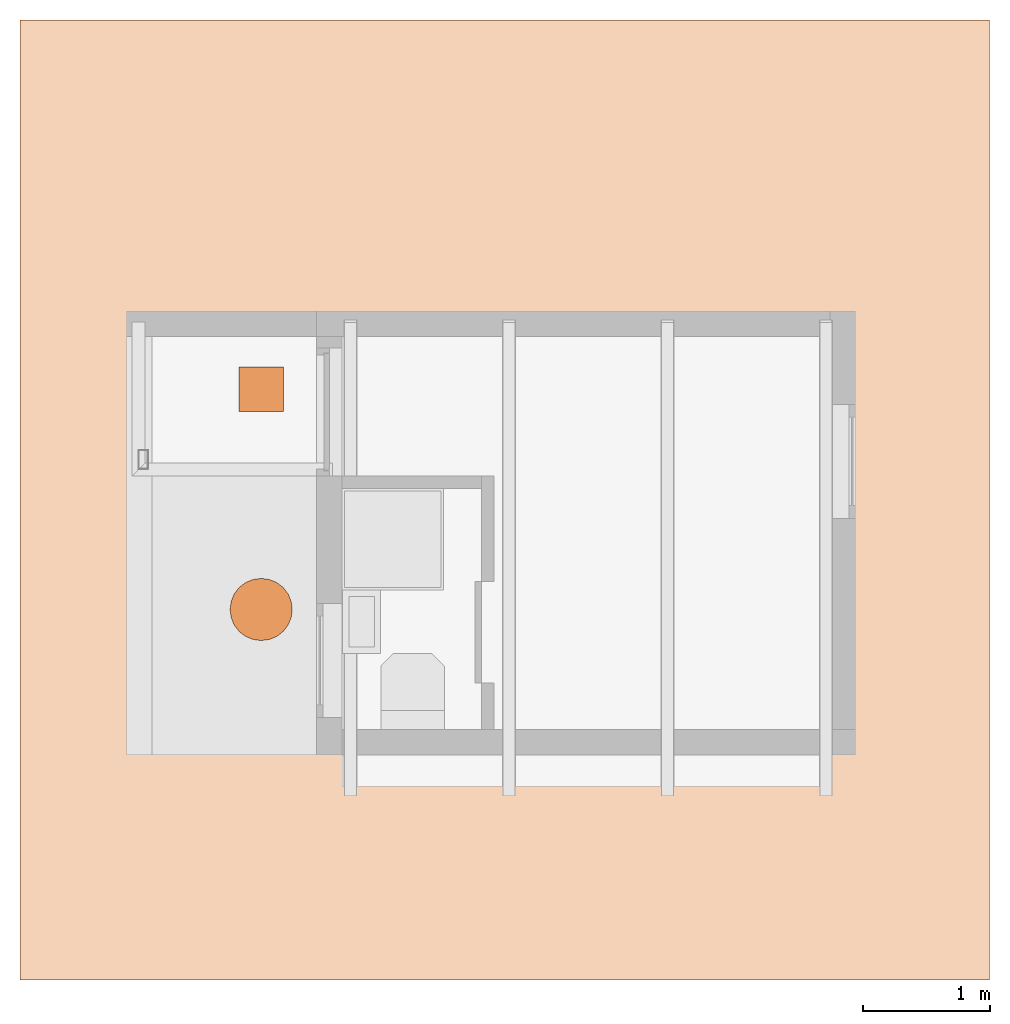
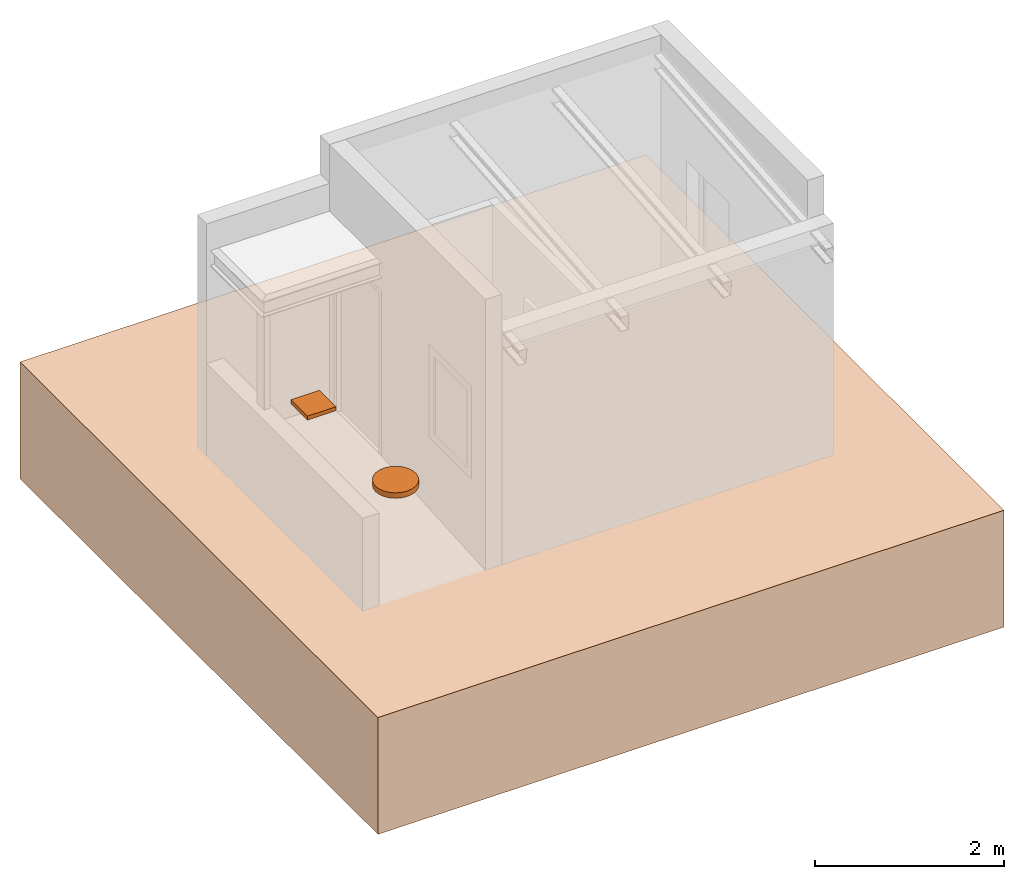
# Not in any storey, part 5 of 5: 2 proxies, 1 geographic element.
"""IFC4 model written with IfcOpenShell, lengths in millimetres."""

import ifcopenshell
import ifcopenshell.guid

model = None  # the IFC model being written
_history = None  # IfcOwnerHistory: only IFC2X3 demands one
_inside = {}  # id of a spatial element -> (the spatial element, [elements in it])
_under = {}  # id of a project, library or spatial element -> (it, [spatial elements below it])
_declared = {}  # id of a project -> (the project, [libraries it declares])
_typed = {}  # id of a type object -> (the type object, [elements of that type])
_made_of = {}  # id of a material, layer set ... -> (it, [elements and type objects made of it])


def new_model(schema):
    """Start an empty IFC model of exactly this schema.

    Asked for "IFC4X3", IfcOpenShell would pick the latest addendum, in which some entities
    have other attributes; the version numbers below select the first issue.
    IFC2X3 requires an IfcOwnerHistory on every rooted entity: one is made here for all.
    """
    global model, _history
    if schema == "IFC4X3":
        model = ifcopenshell.file(schema_version=(4, 3, 0, 0))
    else:
        model = ifcopenshell.file(schema=schema)
    _inside.clear()
    _under.clear()
    _declared.clear()
    _typed.clear()
    _made_of.clear()
    _history = None
    if model.schema == "IFC2X3":
        org = make("IfcOrganization", Name="unknown")
        user = make(
            "IfcPersonAndOrganization",
            ThePerson=make("IfcPerson", FamilyName="unknown"),
            TheOrganization=org,
        )
        app = make(
            "IfcApplication",
            ApplicationDeveloper=org,
            Version="unknown",
            ApplicationFullName="unknown",
            ApplicationIdentifier="unknown",
        )
        _history = make(
            "IfcOwnerHistory",
            OwningUser=user,
            OwningApplication=app,
            ChangeAction="ADDED",
            CreationDate=0,
        )
    return model


def make(cls, **values):
    """One entity of the class cls with the attributes given. An attribute that is None is left unset."""
    return model.create_entity(
        cls, **{name: value for name, value in values.items() if value is not None}
    )


def entity(cls, *values):
    """Any entity or typed value of the class cls, its attributes in the order of the schema. None: left unset."""
    e = model.create_entity(cls)
    for i, value in enumerate(values):
        if value is not None:
            e[i] = value
    return e


def rooted(cls, **values):
    """An entity with a GlobalId (a new one), such as an element, a storey or a relation."""
    return make(cls, GlobalId=ifcopenshell.guid.new(), OwnerHistory=_history, **values)


def si_unit(unit_type, name, prefix=None):
    """IfcSIUnit, for example si_unit("LENGTHUNIT", "METRE", prefix="MILLI")."""
    return make("IfcSIUnit", UnitType=unit_type, Prefix=prefix, Name=name)


def converted_unit(unit_type, name, factor, base, dimensions=None, offset=None):
    """IfcConversionBasedUnit, such as the inch: factor (a typed value) times the base unit."""
    return make(
        "IfcConversionBasedUnit"
        if offset is None
        else "IfcConversionBasedUnitWithOffset",
        ConversionOffset=offset,
        Dimensions=None
        if dimensions is None
        else entity("IfcDimensionalExponents", *dimensions),
        UnitType=unit_type,
        Name=name,
        ConversionFactor=make(
            "IfcMeasureWithUnit", ValueComponent=factor, UnitComponent=base
        ),
    )


def assignment(units):
    """IfcUnitAssignment: the units of a project."""
    return None if units is None else make("IfcUnitAssignment", Units=units)


def point(xyz):
    """IfcCartesianPoint."""
    return None if xyz is None else make("IfcCartesianPoint", Coordinates=xyz)


def direction(xyz):
    """IfcDirection."""
    return None if xyz is None else make("IfcDirection", DirectionRatios=xyz)


def frame(location, z_axis=None, x_axis=None):
    """IfcAxis2Placement3D, a coordinate frame: its origin and axes. An axis left out is left unset."""
    return make(
        "IfcAxis2Placement3D",
        Location=point(location),
        Axis=direction(z_axis),
        RefDirection=direction(x_axis),
    )


def frame_2d(location, x_axis=None):
    """IfcAxis2Placement2D, a coordinate frame in the plane: its origin and x axis."""
    return make(
        "IfcAxis2Placement2D", Location=point(location), RefDirection=direction(x_axis)
    )


def origin_with_axes():
    """The frame at (0, 0, 0) with the z axis (0, 0, 1) and the x axis (1, 0, 0) written out."""
    return frame((0.0, 0.0, 0.0), z_axis=(0.0, 0.0, 1.0), x_axis=(1.0, 0.0, 0.0))


def origin_2d_with_axis():
    """The frame at (0, 0) in the plane with the x axis (1, 0) written out."""
    return frame_2d((0.0, 0.0), x_axis=(1.0, 0.0))


def place(relative_to, where):
    """IfcLocalPlacement: puts the frame where relative to a parent placement (None: the world)."""
    return make(
        "IfcLocalPlacement", PlacementRelTo=relative_to, RelativePlacement=where
    )


def context(
    kind, dimensions, precision=None, world=None, true_north=None, identifier=None
):
    """IfcGeometricRepresentationContext, for example the 3D "Model" context."""
    return make(
        "IfcGeometricRepresentationContext",
        ContextIdentifier=identifier,
        ContextType=kind,
        CoordinateSpaceDimension=dimensions,
        Precision=precision,
        WorldCoordinateSystem=world,
        TrueNorth=true_north,
    )


def subcontext(parent, identifier, kind, view, scale=None):
    """IfcGeometricRepresentationSubContext, for example "Body" below "Model"."""
    return make(
        "IfcGeometricRepresentationSubContext",
        ContextIdentifier=identifier,
        ContextType=kind,
        ParentContext=parent,
        TargetScale=scale,
        TargetView=view,
    )


def project(units=None, contexts=None):
    """IfcProject with its units and contexts."""
    return rooted(
        "IfcProject",
        Name="project",
        RepresentationContexts=contexts,
        UnitsInContext=assignment(units),
    )


def point_list(points):
    """IfcCartesianPointList2D or 3D."""
    cls = (
        "IfcCartesianPointList2D" if len(points[0]) == 2 else "IfcCartesianPointList3D"
    )
    return make(cls, CoordList=points)


def polygons(points, faces, closed=None, point_numbers=None):
    """IfcPolygonalFaceSet: a face is its outer loop, then its inner loops; points numbered from 1."""
    made = []
    for loops in faces:
        if len(loops) == 1:
            made.append(make("IfcIndexedPolygonalFace", CoordIndex=loops[0]))
        else:
            made.append(
                make(
                    "IfcIndexedPolygonalFaceWithVoids",
                    CoordIndex=loops[0],
                    InnerCoordIndices=loops[1:],
                )
            )
    return make(
        "IfcPolygonalFaceSet",
        Coordinates=point_list(points),
        Closed=closed,
        Faces=made,
        PnIndex=point_numbers,
    )


def shape(context_of_items, identifier, shape_type, items):
    """IfcShapeRepresentation: the items that make up one representation, for example the "Body"."""
    return make(
        "IfcShapeRepresentation",
        ContextOfItems=context_of_items,
        RepresentationIdentifier=identifier,
        RepresentationType=shape_type,
        Items=items,
    )


def source(mapping_origin, context_of_items, identifier, shape_type, items):
    """IfcRepresentationMap: a shape defined once, which mapped items show again and again."""
    return make(
        "IfcRepresentationMap",
        MappingOrigin=mapping_origin,
        MappedRepresentation=shape(context_of_items, identifier, shape_type, items),
    )


def transform(
    local_origin,
    x_axis=None,
    y_axis=None,
    z_axis=None,
    scale=None,
    scale2=None,
    scale3=None,
    uniform=True,
):
    """IfcCartesianTransformationOperator3D, or its non-uniform kind. x_axis, y_axis, z_axis: its Axis1, 2, 3."""
    if uniform:
        return make(
            "IfcCartesianTransformationOperator3D",
            Axis1=direction(x_axis),
            Axis2=direction(y_axis),
            LocalOrigin=point(local_origin),
            Scale=scale,
            Axis3=direction(z_axis),
        )
    return make(
        "IfcCartesianTransformationOperator3DnonUniform",
        Axis1=direction(x_axis),
        Axis2=direction(y_axis),
        LocalOrigin=point(local_origin),
        Scale=scale,
        Axis3=direction(z_axis),
        Scale2=scale2,
        Scale3=scale3,
    )


def mapped(mapping_source, mapping_target):
    """IfcMappedItem: shows the shape of a source again, moved by a transform."""
    return make(
        "IfcMappedItem", MappingSource=mapping_source, MappingTarget=mapping_target
    )


def material(Name=None, Category=None):
    """IfcMaterial."""
    return make("IfcMaterial", Name=Name, Category=Category)


def made_of(thing, what):
    """Note that an element or type object is made of a material, layer set ...; save() writes the relation."""
    if what is not None:
        _made_of.setdefault(what.id(), (what, []))[1].append(thing)
    return thing


def type_object(cls, material=None, **own):
    """A type object (cls), such as IfcWallType, which elements share."""
    return made_of(rooted(cls, **own), material)


def type_shapes(of_type, sources):
    """Give a type object the sources (RepresentationMaps) that its elements show as mapped items."""
    of_type.RepresentationMaps = sources


def element(
    cls,
    number,
    at=None,
    inside=None,
    cuts=None,
    type_object=None,
    material=None,
    context=None,
    identifier="Body",
    shape_type=None,
    held_by="IfcProductDefinitionShape",
    body=None,
    shapes=None,
    **own,
):
    """One element of the class cls, such as IfcWall. Its Tag is "e" and its number.

    at: its placement. inside: the storey or other place that contains it. cuts: it is an
    opening in that element (IfcRelVoidsElement). A single representation is given by context,
    identifier, shape_type and body (its items); several are given by shapes. held_by: the class
    of the entity that holds the representations. save() writes the other relations.
    """
    e = rooted(cls, Tag="e%d" % number, ObjectPlacement=at, **own)
    if body is not None:
        shapes = [shape(context, identifier, shape_type, body)]
    if shapes is not None:
        e.Representation = make(held_by, Representations=shapes)
    if inside is not None:
        _inside.setdefault(inside.id(), (inside, []))[1].append(e)
    if cuts is not None:
        rooted(
            "IfcRelVoidsElement", RelatingBuildingElement=cuts, RelatedOpeningElement=e
        )
    if type_object is not None:
        _typed.setdefault(type_object.id(), (type_object, []))[1].append(e)
    return made_of(e, material)


def aggregate(whole, parts):
    """IfcRelAggregates: a whole, such as a stair, and the parts it consists of."""
    return rooted("IfcRelAggregates", RelatingObject=whole, RelatedObjects=parts)


def save(model, path):
    """Write the relations noted so far, then the file.

    IfcRelAggregates (storeys below a building ...), IfcRelContainedInSpatialStructure (elements
    in a storey), IfcRelDefinesByType, IfcRelAssociatesMaterial and IfcRelDeclares: one each for
    every whole, place, type object, material and project.
    """
    for whole, parts in _under.values():
        aggregate(whole, parts)
    for where, things in _inside.values():
        rooted(
            "IfcRelContainedInSpatialStructure",
            RelatedElements=things,
            RelatingStructure=where,
        )
    for kind, things in _typed.values():
        rooted("IfcRelDefinesByType", RelatedObjects=things, RelatingType=kind)
    for what, things in _made_of.values():
        rooted("IfcRelAssociatesMaterial", RelatedObjects=things, RelatingMaterial=what)
    for by, libraries in _declared.values():
        rooted("IfcRelDeclares", RelatingContext=by, RelatedDefinitions=libraries)
    model.write(path)


model = new_model("IFC4")

# Units and contexts
model_context = context("Model", 3, precision=1e-05, world=origin_with_axes())
plan_context = context("Plan", 2, precision=1e-05, world=origin_2d_with_axis())
body_context = subcontext(model_context, "Body", "Model", "MODEL_VIEW")
ifc_project = project(units=[converted_unit("PLANEANGLEUNIT", "degree", entity("IfcReal", 0.0174532925199433), si_unit("PLANEANGLEUNIT", "RADIAN"), dimensions=[0, 0, 0, 0, 0, 0, 0]), si_unit("AREAUNIT", "SQUARE_METRE"), si_unit("VOLUMEUNIT", "CUBIC_METRE"), si_unit("LENGTHUNIT", "METRE", prefix="MILLI")], contexts=[model_context, plan_context])

# Proxies
building_element_proxy_type_1 = type_object("IfcBuildingElementProxyType", Name="Rectangle Tag - 1:50", PredefinedType="COMPLEX")
shared_shape_1 = source(origin_with_axes(), body_context, "Body", "Tessellation", [
    polygons([(-174.999877929688, -174.999954223633, -24.9999732971191), (-174.999877929688, 174.999954223633, -24.9999732971191), (-174.999877929688, -174.999954223633, 24.9999732971191), (-174.999877929688, 174.999954223633, 24.9999732971191), (175.000030517578, 174.999954223633, -24.9999732971191), (175.000030517578, 174.999954223633, 24.9999732971191), (175.000030517578, -174.999954223633, -24.9999732971191), (175.000030517578, -174.999954223633, 24.9999732971191)], [[[3, 2, 1]], [[3, 4, 2]], [[6, 5, 2]], [[6, 2, 4]], [[6, 7, 5]], [[6, 8, 7]], [[7, 8, 3]], [[7, 3, 1]], [[2, 5, 7]], [[2, 7, 1]], [[6, 4, 3]], [[6, 3, 8]]]),
])
type_shapes(building_element_proxy_type_1, [shared_shape_1])
proxy_1_placement = place(None, frame((-437.147080898285, 2881.8724155426, 393.21556687355), z_axis=(0.0, 0.0, 1.0), x_axis=(1.0, 0.0, 0.0)))
element("IfcBuildingElementProxy", 1, at=proxy_1_placement, type_object=building_element_proxy_type_1, PredefinedType="COMPLEX", context=body_context, shape_type="MappedRepresentation", body=[
    mapped(shared_shape_1, transform((0.0, 0.0, 0.0), x_axis=(1.0, 0.0, 0.0), y_axis=(0.0, 1.0, 0.0), z_axis=(0.0, 0.0, 1.0), scale=1.0)),
])
building_element_proxy_type_2 = type_object("IfcBuildingElementProxyType", Name="Tag Circle - 980 - 1:50", PredefinedType="COMPLEX")
shared_shape_2 = source(origin_with_axes(), body_context, "Body", "Tessellation", [
    polygons([(-1.85985767841339, -244.999847412109, -34.9999847412109), (-1.85985767841339, -244.999847412109, 35.0000076293945), (1.8597697019577, -244.999847412109, -34.9999847412109), (1.8597697019577, -244.999847412109, 35.0000076293945), (1.8597697019577, 245.000030517578, -34.9999847412109), (1.8597697019577, 245.000030517578, 35.0000076293945), (-1.85985767841339, 245.000030517578, -34.9999847412109), (-1.85985767841339, 245.000030517578, 35.0000076293945), (-64.7891464233398, -236.715057373047, -34.9999847412109), (-123.42992401123, -212.425247192383, -34.9999847412109), (-173.785873413086, -173.785766601562, -34.9999847412109), (-212.425384521484, -123.429817199707, -34.9999847412109), (-236.715148925781, -64.7890319824219, -34.9999847412109), (-244.999969482422, -1.8597309589386, -34.9999847412109), (-244.999969482422, 1.85989630222321, -34.9999847412109), (-236.715148925781, 64.789176940918, -34.9999847412109), (-212.425384521484, 123.429954528809, -34.9999847412109), (-173.785873413086, 173.785934448242, -34.9999847412109), (-123.42992401123, 212.425445556641, -34.9999847412109), (-64.7891464233398, 236.715209960938, -34.9999847412109), (64.7890701293945, 236.715209960938, -34.9999847412109), (123.42985534668, 212.425445556641, -34.9999847412109), (173.78581237793, 173.785934448242, -34.9999847412109), (212.42529296875, 123.429954528809, -34.9999847412109), (236.715103149414, 64.789176940918, -34.9999847412109), (244.999877929688, 1.85989630222321, -34.9999847412109), (244.999877929688, -1.8597309589386, -34.9999847412109), (236.715103149414, -64.7890319824219, -34.9999847412109), (212.42529296875, -123.429817199707, -34.9999847412109), (173.78581237793, -173.785766601562, -34.9999847412109), (123.42985534668, -212.425247192383, -34.9999847412109), (64.7890701293945, -236.715057373047, -34.9999847412109), (-244.999969482422, 1.85989630222321, 35.0000076293945), (-244.999969482422, -1.8597309589386, 35.0000076293945), (-236.715148925781, -64.7890319824219, 35.0000076293945), (-212.425384521484, -123.429817199707, 35.0000076293945), (-173.785873413086, -173.785766601562, 35.0000076293945), (-123.42992401123, -212.425247192383, 35.0000076293945), (-64.7891464233398, -236.715057373047, 35.0000076293945), (64.7890701293945, -236.715057373047, 35.0000076293945), (123.42985534668, -212.425247192383, 35.0000076293945), (173.78581237793, -173.785766601562, 35.0000076293945), (212.42529296875, -123.429817199707, 35.0000076293945), (236.715103149414, -64.7890319824219, 35.0000076293945), (244.999877929688, -1.8597309589386, 35.0000076293945), (244.999877929688, 1.85989630222321, 35.0000076293945), (236.715103149414, 64.789176940918, 35.0000076293945), (212.42529296875, 123.429954528809, 35.0000076293945), (173.78581237793, 173.785934448242, 35.0000076293945), (123.42985534668, 212.425445556641, 35.0000076293945), (64.7890701293945, 236.715209960938, 35.0000076293945), (-64.7891464233398, 236.715209960938, 35.0000076293945), (-123.42992401123, 212.425445556641, 35.0000076293945), (-173.785873413086, 173.785934448242, 35.0000076293945), (-212.425384521484, 123.429954528809, 35.0000076293945), (-236.715148925781, 64.789176940918, 35.0000076293945)], [[[1, 3, 4]], [[1, 4, 2]], [[5, 7, 8]], [[5, 8, 6]], [[29, 30, 31]], [[3, 31, 32]], [[3, 29, 31]], [[27, 28, 29]], [[27, 29, 3]], [[1, 27, 3]], [[26, 27, 1]], [[24, 25, 26]], [[10, 1, 9]], [[11, 1, 10]], [[13, 11, 12]], [[13, 1, 11]], [[21, 22, 23]], [[21, 23, 24]], [[21, 24, 26]], [[14, 1, 13]], [[5, 21, 26]], [[15, 26, 1]], [[15, 1, 14]], [[7, 26, 15]], [[7, 5, 26]], [[16, 7, 15]], [[20, 7, 16]], [[18, 16, 17]], [[18, 19, 20]], [[18, 20, 16]], [[43, 41, 42]], [[4, 40, 41]], [[4, 41, 43]], [[45, 43, 44]], [[45, 4, 43]], [[2, 4, 45]], [[46, 2, 45]], [[48, 46, 47]], [[38, 39, 2]], [[37, 38, 2]], [[35, 36, 37]], [[35, 37, 2]], [[51, 48, 49]], [[51, 49, 50]], [[51, 46, 48]], [[34, 35, 2]], [[6, 46, 51]], [[33, 2, 46]], [[33, 34, 2]], [[8, 33, 46]], [[8, 46, 6]], [[56, 33, 8]], [[52, 56, 8]], [[54, 52, 53]], [[54, 55, 56]], [[54, 56, 52]], [[46, 45, 27]], [[46, 27, 26]], [[21, 5, 6]], [[21, 6, 51]], [[22, 21, 51]], [[22, 51, 50]], [[23, 22, 50]], [[23, 50, 49]], [[49, 24, 23]], [[49, 48, 24]], [[48, 25, 24]], [[48, 47, 25]], [[47, 26, 25]], [[47, 46, 26]], [[3, 40, 4]], [[3, 32, 40]], [[32, 41, 40]], [[32, 31, 41]], [[31, 42, 41]], [[31, 30, 42]], [[43, 42, 30]], [[43, 30, 29]], [[44, 43, 29]], [[44, 29, 28]], [[45, 44, 28]], [[45, 28, 27]], [[9, 1, 2]], [[9, 2, 39]], [[10, 9, 39]], [[10, 39, 38]], [[11, 10, 38]], [[11, 38, 37]], [[37, 12, 11]], [[37, 36, 12]], [[36, 13, 12]], [[36, 35, 13]], [[35, 14, 13]], [[35, 34, 14]], [[7, 52, 8]], [[7, 20, 52]], [[20, 53, 52]], [[20, 19, 53]], [[19, 54, 53]], [[19, 18, 54]], [[55, 54, 18]], [[55, 18, 17]], [[56, 55, 17]], [[56, 17, 16]], [[33, 56, 16]], [[33, 16, 15]], [[14, 33, 15]], [[14, 34, 33]]]),
])
type_shapes(building_element_proxy_type_2, [shared_shape_2])
proxy_2_placement = place(None, frame((-437.136203050613, 1146.07632160187, 450.000047683716), z_axis=(0.0, 0.0, 1.0), x_axis=(1.0, 0.0, 0.0)))
element("IfcBuildingElementProxy", 2, at=proxy_2_placement, type_object=building_element_proxy_type_2, context=body_context, shape_type="MappedRepresentation", body=[
    mapped(shared_shape_2, transform((0.0, 0.0, 0.0), x_axis=(1.0, 0.0, 0.0), y_axis=(0.0, 1.0, 0.0), z_axis=(0.0, 0.0, 1.0), scale=1.0)),
])

# Geographic element
ifc_material = material(Name="earth")
geographic_element_placement = place(None, frame((4050.00066757202, 2204.46014404297, -1149.99997615814), z_axis=(0.0, 0.0, 1.0), x_axis=(1.0, 0.0, 0.0)))
element("IfcGeographicElement", 3, at=geographic_element_placement, material=ifc_material, Name="Cube", PredefinedType="TERRAIN", context=body_context, shape_type="Tessellation", body=[
    polygons([(1256.02136230469, 3591.265625, -508.349639892578), (1256.02136230469, -3980.8115234375, -508.349639892578), (1256.02136230469, 3591.265625, 999.999755859375), (1256.02136230469, -3980.8115234375, 999.999755859375), (-6389.2578125, -3980.8115234375, 999.999755859375), (-6389.2578125, 3591.265625, 999.999755859375), (-6389.2578125, 3591.265625, -508.349639892578), (-6389.2578125, -3980.8115234375, -508.349639892578)], [[[6, 7, 8, 5]], [[6, 3, 1, 7]], [[5, 8, 2, 4]], [[2, 8, 7, 1]], [[5, 4, 3, 6]], [[1, 3, 4, 2]]], closed=True),
])

save(model, "model.ifc")
